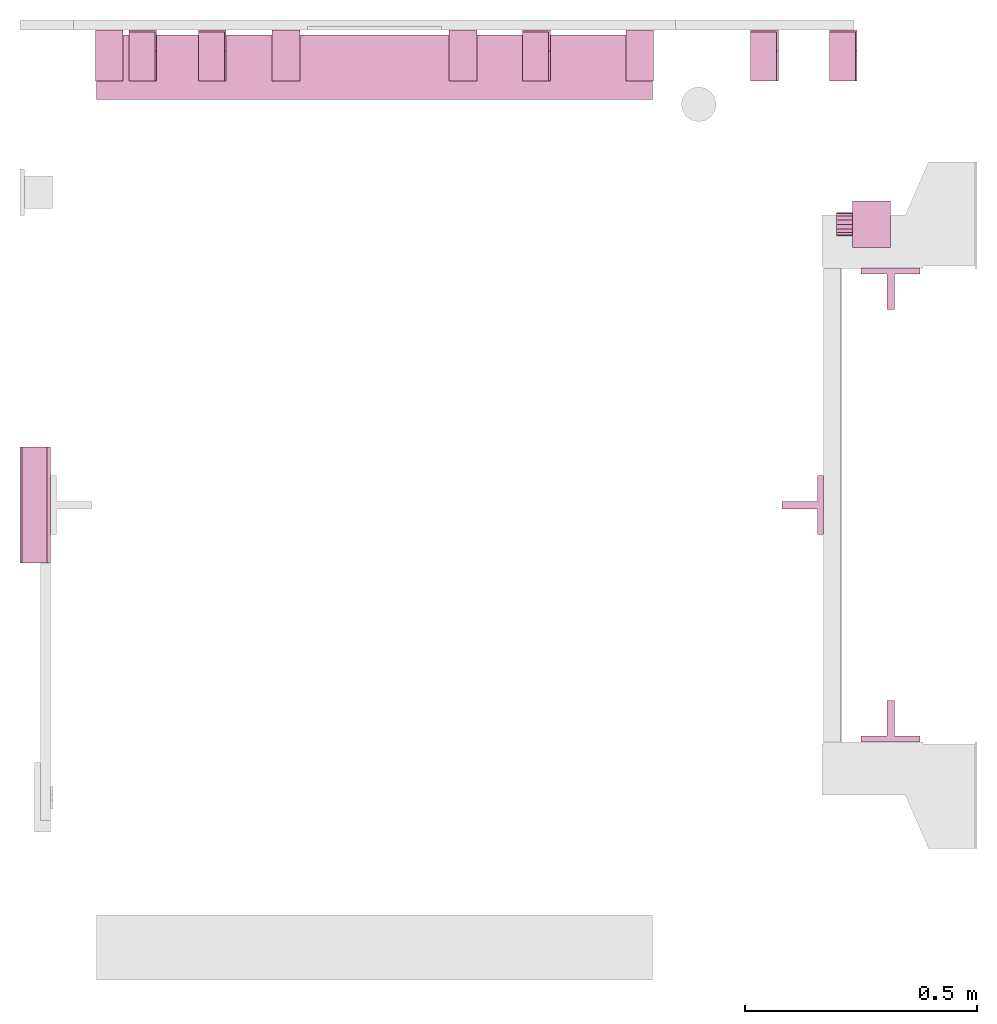
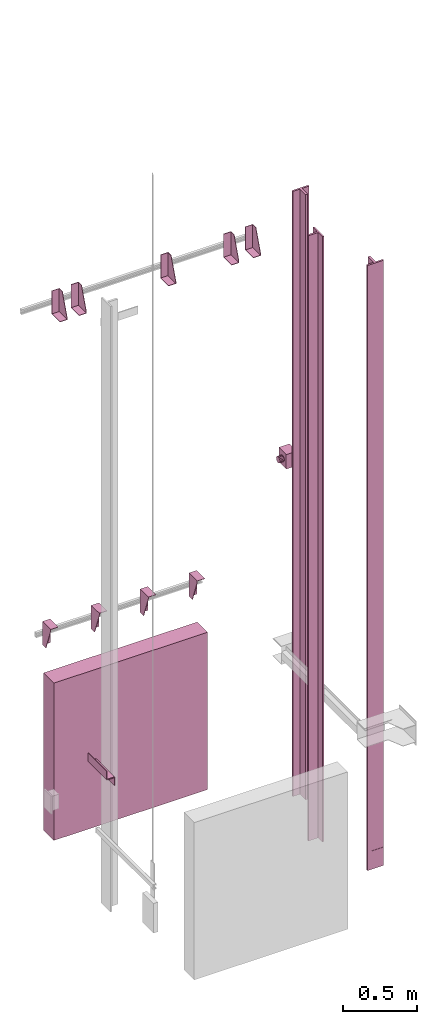
# One storey, part 5 of 5: 15 transport elements.
"""IFC4 building model written with IfcOpenShell, lengths in millimetres."""

from ifc_helpers import new_model, entity, si_unit, converted_unit, frame, origin_with_axes, place, context, subcontext, project, spatial, faceted_brep, element, save


model = new_model("IFC4")

# Units and contexts
context_of_model = context(None, 3, precision=0.01, world=origin_with_axes())
sub_context_1 = subcontext(context_of_model, None, None, "MODEL_VIEW")
sub_context_2 = subcontext(context_of_model, None, None, "MODEL_VIEW")
sub_context_3 = subcontext(context_of_model, None, None, "MODEL_VIEW")
sub_context_4 = subcontext(context_of_model, None, None, "MODEL_VIEW")
sub_context_5 = subcontext(context_of_model, None, None, "MODEL_VIEW")
sub_context_6 = subcontext(context_of_model, None, None, "MODEL_VIEW")
sub_context_7 = subcontext(context_of_model, None, None, "MODEL_VIEW")
sub_context_8 = subcontext(context_of_model, None, None, "MODEL_VIEW")
sub_context_9 = subcontext(context_of_model, None, None, "MODEL_VIEW")
sub_context_10 = subcontext(context_of_model, None, None, "MODEL_VIEW")
sub_context_11 = subcontext(context_of_model, None, None, "MODEL_VIEW")
sub_context_12 = subcontext(context_of_model, None, None, "MODEL_VIEW")
sub_context_13 = subcontext(context_of_model, None, None, "MODEL_VIEW")
sub_context_14 = subcontext(context_of_model, None, None, "MODEL_VIEW")
sub_context_15 = subcontext(context_of_model, None, None, "MODEL_VIEW")
ifc_project = project(units=[converted_unit("PLANEANGLEUNIT", "degree", entity("IfcPlaneAngleMeasure", 0.017453292519943), si_unit("PLANEANGLEUNIT", "RADIAN"), dimensions=[0, 0, 0, 0, 0, 0, 0]), si_unit("LENGTHUNIT", "METRE", prefix="MILLI"), si_unit("MASSUNIT", "GRAM", prefix="KILO"), converted_unit("TIMEUNIT", "year", entity("IfcTimeMeasure", 31557600.0), si_unit("TIMEUNIT", "SECOND"), dimensions=[0, 0, 1, 0, 0, 0, 0]), si_unit("THERMODYNAMICTEMPERATUREUNIT", "DEGREE_CELSIUS"), si_unit("AREAUNIT", "SQUARE_METRE"), si_unit("FORCEUNIT", "NEWTON"), si_unit("VOLUMEUNIT", "CUBIC_METRE"), si_unit("PRESSUREUNIT", "PASCAL"), si_unit("SOLIDANGLEUNIT", "STERADIAN")], contexts=[context_of_model])

# Site, building, storey
site = spatial("IfcSite", under=ifc_project)
building = spatial("IfcBuilding", under=site, Name="Document")
placement = place(None, origin_with_axes())
storey_placement = place(placement, frame((0.0, 0.0, -24650.0), z_axis=(0.0, 0.0, 1.0), x_axis=(1.0, 0.0, 0.0)))
storey = spatial("IfcBuildingStorey", under=building, at=storey_placement, Name="P11", Elevation=-24650.0)

# Transport elements
transport_element_1_placement = place(storey_placement, frame((1879.0, 558.5, 763.0), z_axis=(0.0, -1.0, 0.0), x_axis=(0.0, 0.0, -1.0)))
element("IfcTransportElement", 1, at=transport_element_1_placement, inside=storey, ObjectType="Guide Rail", PredefinedType="ELEVATOR", context=sub_context_1, shape_type="Brep", body=[
    faceted_brep([(-2500.0, -63.5, 44.5), (-2500.0, -63.5, 31.79998779296875), (2500.0, -63.5, 31.79998779296875), (2500.0, -63.5, 44.5), (-2500.0, -7.93994140625, 31.79998779296875), (-2500.0, -7.93994140625, -44.5), (2500.0, -7.93994140625, -44.5), (2500.0, -7.93994140625, 31.79998779296875), (2500.0, 7.93994140625, -44.5), (-2500.0, 7.93994140625, -44.5), (-2500.0, 7.93994140625, 31.79998779296875), (2500.0, 7.93994140625, 31.79998779296875), (2500.0, 63.5, 31.79998779296875), (-2500.0, 63.5, 31.79998779296875), (-2500.0, 63.5, 44.5), (2500.0, 63.5, 44.5)], [[[0, 1, 2, 3]], [[4, 5, 6, 7]], [[8, 9, 10, 11]], [[12, 13, 14, 15]], [[15, 14, 0, 3]], [[1, 4, 7, 2]], [[10, 13, 12, 11]], [[5, 9, 8, 6]], [[2, 7, 6, 8, 11, 12, 15, 3]], [[14, 13, 10, 9, 5, 4, 1, 0]]]),
    faceted_brep([(2347.5, -63.5, 45.0), (2347.5, 63.5, 45.0), (2347.5, 63.5, 44.0), (2347.5, -63.5, 44.0), (2500.0, -63.5, 45.0), (2500.0, -63.5, 44.0), (2500.0, 63.5, 44.0), (2500.0, 63.5, 45.0)], [[[0, 1, 2, 3]], [[4, 5, 6, 7]], [[0, 3, 5, 4]], [[3, 2, 6, 5]], [[2, 1, 7, 6]], [[1, 0, 4, 7]]]),
    faceted_brep([(-2500.0, -63.5, 45.0), (-2500.0, 63.5, 45.0), (-2500.0, 63.5, 44.0), (-2500.0, -63.5, 44.0), (-2347.5, -63.5, 45.0), (-2347.5, -63.5, 44.0), (-2347.5, 63.5, 44.0), (-2347.5, 63.5, 45.0)], [[[0, 1, 2, 3]], [[4, 5, 6, 7]], [[0, 3, 5, 4]], [[3, 2, 6, 5]], [[2, 1, 7, 6]], [[1, 0, 4, 7]]]),
])
transport_element_2_placement = place(storey_placement, frame((1879.0, 1491.5, 763.0), z_axis=(0.0, 1.0, 0.0), x_axis=(0.0, 0.0, 1.0)))
element("IfcTransportElement", 2, at=transport_element_2_placement, inside=storey, ObjectType="Guide Rail", PredefinedType="ELEVATOR", context=sub_context_2, shape_type="Brep", body=[
    faceted_brep([(2500.0, -63.5, 31.800048828125), (2500.0, -63.5, 44.5), (-2500.0, -63.5, 44.5), (-2500.0, -63.5, 31.800048828125), (2500.0, -7.93994140625, -44.5), (2500.0, -7.93994140625, 31.800048828125), (-2500.0, -7.93994140625, 31.800048828125), (-2500.0, -7.93994140625, -44.5), (-2500.0, 7.93994140625, 31.800048828125), (2500.0, 7.93994140625, 31.800048828125), (2500.0, 7.93994140625, -44.5), (-2500.0, 7.93994140625, -44.5), (-2500.0, 63.5, 44.5), (2500.0, 63.5, 44.5), (2500.0, 63.5, 31.800048828125), (-2500.0, 63.5, 31.800048828125)], [[[0, 1, 2, 3]], [[4, 5, 6, 7]], [[8, 9, 10, 11]], [[12, 13, 14, 15]], [[6, 5, 0, 3]], [[1, 13, 12, 2]], [[11, 10, 4, 7]], [[9, 8, 15, 14]], [[2, 12, 15, 8, 11, 7, 6, 3]], [[5, 4, 10, 9, 14, 13, 1, 0]]]),
    faceted_brep([(2347.5, -63.5, 45.0), (2347.5, 63.5, 45.0), (2347.5, 63.5, 44.0), (2347.5, -63.5, 44.0), (2500.0, -63.5, 45.0), (2500.0, -63.5, 44.0), (2500.0, 63.5, 44.0), (2500.0, 63.5, 45.0)], [[[0, 1, 2, 3]], [[4, 5, 6, 7]], [[0, 3, 5, 4]], [[3, 2, 6, 5]], [[2, 1, 7, 6]], [[1, 0, 4, 7]]]),
    faceted_brep([(-2500.0, -63.5, 45.0), (-2500.0, 63.5, 45.0), (-2500.0, 63.5, 44.0), (-2500.0, -63.5, 44.0), (-2347.5, -63.5, 45.0), (-2347.5, -63.5, 44.0), (-2347.5, 63.5, 44.0), (-2347.5, 63.5, 45.0)], [[[0, 1, 2, 3]], [[4, 5, 6, 7]], [[0, 3, 5, 4]], [[3, 2, 6, 5]], [[2, 1, 7, 6]], [[1, 0, 4, 7]]]),
])
transport_element_3_placement = place(storey_placement, frame((1689.5, 1025.0, 763.0), z_axis=(1.0, 0.0, 0.0), x_axis=(0.0, 0.0, 1.0)))
element("IfcTransportElement", 3, at=transport_element_3_placement, inside=storey, ObjectType="Guide Rail", PredefinedType="ELEVATOR", context=sub_context_3, shape_type="Brep", body=[
    faceted_brep([(2500.0, 7.94000244140625, -44.5), (2500.0, -7.93994140625, -44.5), (-2500.0, -7.93994140625, -44.5), (-2500.0, 7.94000244140625, -44.5), (2500.0, 63.5, 31.800048828125), (2500.0, 7.94000244140625, 31.800048828125), (-2500.0, 7.94000244140625, 31.800048828125), (-2500.0, 63.5, 31.800048828125), (-2500.0, -63.5, 44.5), (2500.0, -63.5, 44.5), (2500.0, 63.5, 44.5), (-2500.0, 63.5, 44.5), (2500.0, -7.93994140625, 31.800048828125), (2500.0, -63.5, 31.800048828125), (-2500.0, -63.5, 31.800048828125), (-2500.0, -7.93994140625, 31.800048828125)], [[[0, 1, 2, 3]], [[4, 5, 6, 7]], [[8, 9, 10, 11]], [[12, 13, 14, 15]], [[6, 5, 0, 3]], [[1, 12, 15, 2]], [[11, 10, 4, 7]], [[13, 9, 8, 14]], [[2, 15, 14, 8, 11, 7, 6, 3]], [[5, 4, 10, 9, 13, 12, 1, 0]]]),
    faceted_brep([(2347.5, -63.5, 45.0), (2347.5, 63.5, 45.0), (2347.5, 63.5, 44.0), (2347.5, -63.5, 44.0), (2500.0, -63.5, 45.0), (2500.0, -63.5, 44.0), (2500.0, 63.5, 44.0), (2500.0, 63.5, 45.0)], [[[0, 1, 2, 3]], [[4, 5, 6, 7]], [[0, 3, 5, 4]], [[3, 2, 6, 5]], [[2, 1, 7, 6]], [[1, 0, 4, 7]]]),
    faceted_brep([(-2500.0, -63.5, 45.0), (-2500.0, 63.5, 45.0), (-2500.0, 63.5, 44.0), (-2500.0, -63.5, 44.0), (-2347.5, -63.5, 45.0), (-2347.5, -63.5, 44.0), (-2347.5, 63.5, 44.0), (-2347.5, 63.5, 45.0)], [[[0, 1, 2, 3]], [[4, 5, 6, 7]], [[0, 3, 5, 4]], [[3, 2, 6, 5]], [[2, 1, 7, 6]], [[1, 0, 4, 7]]]),
])
transport_element_4_placement = place(storey_placement, frame((765.0, 1970.0, -1750.0), z_axis=(0.0, 0.0, 1.0), x_axis=(1.0, 0.0, 0.0)))
element("IfcTransportElement", 4, at=transport_element_4_placement, inside=storey, PredefinedType="ELEVATOR", context=sub_context_4, shape_type="Brep", body=[
    faceted_brep([(-600.0, -70.0, 1300.0), (-600.0, 70.0, 1300.0), (-600.0, 70.0, 0.0), (-600.0, -70.0, 0.0), (600.0, -70.0, 1300.0), (600.0, -70.0, 0.0), (600.0, 70.0, 0.0), (600.0, 70.0, 1300.0)], [[[0, 1, 2, 3]], [[4, 5, 6, 7]], [[0, 3, 5, 4]], [[3, 2, 6, 5]], [[2, 1, 7, 6]], [[1, 0, 4, 7]]]),
])
transport_element_5_placement = place(storey_placement, frame((1777.0, 2050.0, 2580.0), z_axis=(0.0, 0.0, 1.0), x_axis=(-1.0, 0.0, 0.0)))
element("IfcTransportElement", 5, at=transport_element_5_placement, inside=storey, PredefinedType="ELEVATOR", context=sub_context_5, shape_type="Brep", body=[
    faceted_brep([(30.0, 110.0, -93.0), (30.0, 4.0, -93.0), (30.0, 4.0, 97.0), (30.0, 0.0, 97.0), (30.0, 0.0, -97.0), (30.0, 110.0, -97.0), (-30.0, 0.0, -97.0), (-30.0, 0.0, 97.0), (-30.0, 4.0, 97.0), (-30.0, 4.0, -93.0), (-30.0, 110.0, -93.0), (-30.0, 110.0, -97.0)], [[[0, 1, 2, 3, 4, 5]], [[6, 7, 8, 9, 10, 11]], [[11, 10, 0, 5]], [[9, 8, 2, 1]], [[3, 7, 6, 4]], [[4, 6, 11, 5]], [[10, 9, 1, 0]], [[8, 7, 3, 2]]]),
    faceted_brep([(-30.0, 4.0, -93.0), (-30.0, 4.0, 97.0), (-30.0, 45.0, 97.0), (-30.0, 110.0, -82.0), (-30.0, 110.0, -93.0), (-26.0, 4.0, -93.0), (-26.0, 110.0, -93.0), (-26.0, 110.0, -82.0), (-26.0, 45.0, 97.0), (-26.0, 4.0, 97.0)], [[[0, 1, 2, 3, 4]], [[5, 6, 7, 8, 9]], [[5, 0, 4, 6]], [[6, 4, 3, 7]], [[7, 3, 2, 8]], [[8, 2, 1, 9]], [[9, 1, 0, 5]]]),
])
transport_element_6_placement = place(storey_placement, frame((1607.0, 2050.0, 2580.0), z_axis=(0.0, 0.0, 1.0), x_axis=(-1.0, 0.0, 0.0)))
element("IfcTransportElement", 6, at=transport_element_6_placement, inside=storey, PredefinedType="ELEVATOR", context=sub_context_6, shape_type="Brep", body=[
    faceted_brep([(30.0, 110.0, -93.0), (30.0, 4.0, -93.0), (30.0, 4.0, 97.0), (30.0, 0.0, 97.0), (30.0, 0.0, -97.0), (30.0, 110.0, -97.0), (-30.0, 0.0, -97.0), (-30.0, 0.0, 97.0), (-30.0, 4.0, 97.0), (-30.0, 4.0, -93.0), (-30.0, 110.0, -93.0), (-30.0, 110.0, -97.0)], [[[0, 1, 2, 3, 4, 5]], [[6, 7, 8, 9, 10, 11]], [[11, 10, 0, 5]], [[9, 8, 2, 1]], [[3, 7, 6, 4]], [[4, 6, 11, 5]], [[10, 9, 1, 0]], [[8, 7, 3, 2]]]),
    faceted_brep([(-30.0, 4.0, -93.0), (-30.0, 4.0, 97.0), (-30.0, 45.0, 97.0), (-30.0, 110.0, -82.0), (-30.0, 110.0, -93.0), (-26.0, 4.0, -93.0), (-26.0, 110.0, -93.0), (-26.0, 110.0, -82.0), (-26.0, 45.0, 97.0), (-26.0, 4.0, 97.0)], [[[0, 1, 2, 3, 4]], [[5, 6, 7, 8, 9]], [[5, 0, 4, 6]], [[6, 4, 3, 7]], [[7, 3, 2, 8]], [[8, 2, 1, 9]], [[9, 1, 0, 5]]]),
])
transport_element_7_placement = place(storey_placement, frame((1115.0, 2050.0, 2580.0), z_axis=(0.0, 0.0, 1.0), x_axis=(-1.0, 0.0, 0.0)))
element("IfcTransportElement", 7, at=transport_element_7_placement, inside=storey, PredefinedType="ELEVATOR", context=sub_context_7, shape_type="Brep", body=[
    faceted_brep([(-30.0, 4.0, -93.0), (-30.0, 4.0, 97.0), (-30.0, 45.0, 97.0), (-30.0, 110.0, -82.0), (-30.0, 110.0, -93.0), (-26.0, 4.0, -93.0), (-26.0, 110.0, -93.0), (-26.0, 110.0, -82.0), (-26.0, 45.0, 97.0), (-26.0, 4.0, 97.0)], [[[0, 1, 2, 3, 4]], [[5, 6, 7, 8, 9]], [[5, 0, 4, 6]], [[6, 4, 3, 7]], [[7, 3, 2, 8]], [[8, 2, 1, 9]], [[9, 1, 0, 5]]]),
    faceted_brep([(30.0, 110.0, -93.0), (30.0, 4.0, -93.0), (30.0, 4.0, 97.0), (30.0, 0.0, 97.0), (30.0, 0.0, -97.0), (30.0, 110.0, -97.0), (-30.0, 0.0, -97.0), (-30.0, 0.0, 97.0), (-30.0, 4.0, 97.0), (-30.0, 4.0, -93.0), (-30.0, 110.0, -93.0), (-30.0, 110.0, -97.0)], [[[0, 1, 2, 3, 4, 5]], [[6, 7, 8, 9, 10, 11]], [[11, 10, 0, 5]], [[9, 8, 2, 1]], [[3, 7, 6, 4]], [[4, 6, 11, 5]], [[10, 9, 1, 0]], [[8, 7, 3, 2]]]),
])
transport_element_8_placement = place(storey_placement, frame((415.0, 2050.0, 2580.0), z_axis=(0.0, 0.0, 1.0), x_axis=(-1.0, 0.0, 0.0)))
element("IfcTransportElement", 8, at=transport_element_8_placement, inside=storey, PredefinedType="ELEVATOR", context=sub_context_8, shape_type="Brep", body=[
    faceted_brep([(30.0, 110.0, -93.0), (30.0, 4.0, -93.0), (30.0, 4.0, 97.0), (30.0, 0.0, 97.0), (30.0, 0.0, -97.0), (30.0, 110.0, -97.0), (-30.0, 0.0, -97.0), (-30.0, 0.0, 97.0), (-30.0, 4.0, 97.0), (-30.0, 4.0, -93.0), (-30.0, 110.0, -93.0), (-30.0, 110.0, -97.0)], [[[0, 1, 2, 3, 4, 5]], [[6, 7, 8, 9, 10, 11]], [[11, 10, 0, 5]], [[9, 8, 2, 1]], [[3, 7, 6, 4]], [[4, 6, 11, 5]], [[10, 9, 1, 0]], [[8, 7, 3, 2]]]),
    faceted_brep([(-30.0, 4.0, -93.0), (-30.0, 4.0, 97.0), (-30.0, 45.0, 97.0), (-30.0, 110.0, -82.0), (-30.0, 110.0, -93.0), (-26.0, 4.0, -93.0), (-26.0, 110.0, -93.0), (-26.0, 110.0, -82.0), (-26.0, 45.0, 97.0), (-26.0, 4.0, 97.0)], [[[0, 1, 2, 3, 4]], [[5, 6, 7, 8, 9]], [[5, 0, 4, 6]], [[6, 4, 3, 7]], [[7, 3, 2, 8]], [[8, 2, 1, 9]], [[9, 1, 0, 5]]]),
])
transport_element_9_placement = place(storey_placement, frame((265.0, 2050.0, 2580.0), z_axis=(0.0, 0.0, 1.0), x_axis=(-1.0, 0.0, 0.0)))
element("IfcTransportElement", 9, at=transport_element_9_placement, inside=storey, PredefinedType="ELEVATOR", context=sub_context_9, shape_type="Brep", body=[
    faceted_brep([(30.0, 110.0, -93.0), (30.0, 4.0, -93.0), (30.0, 4.0, 97.0), (30.0, 0.0, 97.0), (30.0, 0.0, -97.0), (30.0, 110.0, -97.0), (-30.0, 0.0, -97.0), (-30.0, 0.0, 97.0), (-30.0, 4.0, 97.0), (-30.0, 4.0, -93.0), (-30.0, 110.0, -93.0), (-30.0, 110.0, -97.0)], [[[0, 1, 2, 3, 4, 5]], [[6, 7, 8, 9, 10, 11]], [[11, 10, 0, 5]], [[9, 8, 2, 1]], [[3, 7, 6, 4]], [[4, 6, 11, 5]], [[10, 9, 1, 0]], [[8, 7, 3, 2]]]),
    faceted_brep([(-30.0, 4.0, -93.0), (-30.0, 4.0, 97.0), (-30.0, 45.0, 97.0), (-30.0, 110.0, -82.0), (-30.0, 110.0, -93.0), (-26.0, 4.0, -93.0), (-26.0, 110.0, -93.0), (-26.0, 110.0, -82.0), (-26.0, 45.0, 97.0), (-26.0, 4.0, 97.0)], [[[0, 1, 2, 3, 4]], [[5, 6, 7, 8, 9]], [[5, 0, 4, 6]], [[6, 4, 3, 7]], [[7, 3, 2, 8]], [[8, 2, 1, 9]], [[9, 1, 0, 5]]]),
])
transport_element_10_placement = place(storey_placement, frame((192.5, 2050.0, -30.0), z_axis=(0.0, 0.0, -1.0), x_axis=(1.0, 0.0, 0.0)))
element("IfcTransportElement", 10, at=transport_element_10_placement, inside=storey, PredefinedType="ELEVATOR", context=sub_context_10, shape_type="Brep", body=[
    faceted_brep([(-30.0, 4.0, 4.0), (-30.0, 110.0, 4.0), (-30.0, 110.0, 0.0), (-30.0, 0.0, 0.0), (-30.0, 0.0, 194.0), (-30.0, 4.0, 194.0), (30.0, 0.0, 194.0), (30.0, 0.0, 0.0), (30.0, 110.0, 0.0), (30.0, 110.0, 4.0), (30.0, 4.0, 4.0), (30.0, 4.0, 194.0)], [[[0, 1, 2, 3, 4, 5]], [[6, 7, 8, 9, 10, 11]], [[11, 10, 0, 5]], [[3, 7, 6, 4]], [[9, 8, 2, 1]], [[4, 6, 11, 5]], [[0, 10, 9, 1]], [[8, 7, 3, 2]]]),
    faceted_brep([(-30.0, 4.0, 4.0), (-30.0, 4.0, 194.0), (-30.0, 45.0, 194.0), (-30.0, 110.0, 15.0), (-30.0, 110.0, 4.0), (-26.0, 4.0, 4.0), (-26.0, 110.0, 4.0), (-26.0, 110.0, 15.0), (-26.0, 45.0, 194.0), (-26.0, 4.0, 194.0)], [[[0, 1, 2, 3, 4]], [[5, 6, 7, 8, 9]], [[5, 0, 4, 6]], [[6, 4, 3, 7]], [[7, 3, 2, 8]], [[8, 2, 1, 9]], [[9, 1, 0, 5]]]),
])
transport_element_11_placement = place(storey_placement, frame((573.84, 2050.0, -30.0), z_axis=(0.0, 0.0, -1.0), x_axis=(1.0, 0.0, 0.0)))
element("IfcTransportElement", 11, at=transport_element_11_placement, inside=storey, PredefinedType="ELEVATOR", context=sub_context_11, shape_type="Brep", body=[
    faceted_brep([(-29.999973144531282, 4.0, 4.0), (-29.999973144531282, 110.0, 4.0), (-29.999973144531282, 110.0, 0.0), (-29.999973144531282, 0.0, 0.0), (-29.999973144531282, 0.0, 194.0), (-29.999973144531282, 4.0, 194.0), (30.000026855468718, 0.0, 194.0), (30.000026855468718, 0.0, 0.0), (30.000026855468718, 110.0, 0.0), (30.000026855468718, 110.0, 4.0), (30.000026855468718, 4.0, 4.0), (30.000026855468718, 4.0, 194.0)], [[[0, 1, 2, 3, 4, 5]], [[6, 7, 8, 9, 10, 11]], [[11, 10, 0, 5]], [[3, 7, 6, 4]], [[9, 8, 2, 1]], [[4, 6, 11, 5]], [[0, 10, 9, 1]], [[8, 7, 3, 2]]]),
    faceted_brep([(-29.999973144531282, 4.0, 4.0), (-29.999973144531282, 4.0, 194.0), (-29.999973144531282, 45.0, 194.0), (-29.999973144531282, 110.0, 15.0), (-29.999973144531282, 110.0, 4.0), (-25.999973144531282, 4.0, 4.0), (-25.999973144531282, 110.0, 4.0), (-25.999973144531282, 110.0, 15.0), (-25.999973144531282, 45.0, 194.0), (-25.999973144531282, 4.0, 194.0)], [[[0, 1, 2, 3, 4]], [[5, 6, 7, 8, 9]], [[5, 0, 4, 6]], [[6, 4, 3, 7]], [[7, 3, 2, 8]], [[8, 2, 1, 9]], [[9, 1, 0, 5]]]),
])
transport_element_12_placement = place(storey_placement, frame((956.16, 2050.0, -30.0), z_axis=(0.0, 0.0, -1.0), x_axis=(1.0, 0.0, 0.0)))
element("IfcTransportElement", 12, at=transport_element_12_placement, inside=storey, PredefinedType="ELEVATOR", context=sub_context_12, shape_type="Brep", body=[
    faceted_brep([(-30.000026855468718, 4.0, 4.0), (-30.000026855468718, 4.0, 194.0), (-30.000026855468718, 45.0, 194.0), (-30.000026855468718, 110.0, 15.0), (-30.000026855468718, 110.0, 4.0), (-26.000026855468718, 4.0, 4.0), (-26.000026855468718, 110.0, 4.0), (-26.000026855468718, 110.0, 15.0), (-26.000026855468718, 45.0, 194.0), (-26.000026855468718, 4.0, 194.0)], [[[0, 1, 2, 3, 4]], [[5, 6, 7, 8, 9]], [[5, 0, 4, 6]], [[6, 4, 3, 7]], [[7, 3, 2, 8]], [[8, 2, 1, 9]], [[9, 1, 0, 5]]]),
    faceted_brep([(-30.000026855468718, 4.0, 4.0), (-30.000026855468718, 110.0, 4.0), (-30.000026855468718, 110.0, 0.0), (-30.000026855468718, 0.0, 0.0), (-30.000026855468718, 0.0, 194.0), (-30.000026855468718, 4.0, 194.0), (29.999973144531282, 0.0, 194.0), (29.999973144531282, 0.0, 0.0), (29.999973144531282, 110.0, 0.0), (29.999973144531282, 110.0, 4.0), (29.999973144531282, 4.0, 4.0), (29.999973144531282, 4.0, 194.0)], [[[0, 1, 2, 3, 4, 5]], [[6, 7, 8, 9, 10, 11]], [[11, 10, 0, 5]], [[3, 7, 6, 4]], [[9, 8, 2, 1]], [[4, 6, 11, 5]], [[0, 10, 9, 1]], [[8, 7, 3, 2]]]),
])
transport_element_13_placement = place(storey_placement, frame((1337.5, 2050.0, -30.0), z_axis=(0.0, 0.0, -1.0), x_axis=(1.0, 0.0, 0.0)))
element("IfcTransportElement", 13, at=transport_element_13_placement, inside=storey, PredefinedType="ELEVATOR", context=sub_context_13, shape_type="Brep", body=[
    faceted_brep([(-30.0, 4.0, 4.0), (-30.0, 110.0, 4.0), (-30.0, 110.0, 0.0), (-30.0, 0.0, 0.0), (-30.0, 0.0, 194.0), (-30.0, 4.0, 194.0), (30.0, 0.0, 194.0), (30.0, 0.0, 0.0), (30.0, 110.0, 0.0), (30.0, 110.0, 4.0), (30.0, 4.0, 4.0), (30.0, 4.0, 194.0)], [[[0, 1, 2, 3, 4, 5]], [[6, 7, 8, 9, 10, 11]], [[11, 10, 0, 5]], [[3, 7, 6, 4]], [[9, 8, 2, 1]], [[4, 6, 11, 5]], [[0, 10, 9, 1]], [[8, 7, 3, 2]]]),
    faceted_brep([(-30.0, 4.0, 4.0), (-30.0, 4.0, 194.0), (-30.0, 45.0, 194.0), (-30.0, 110.0, 15.0), (-30.0, 110.0, 4.0), (-26.0, 4.0, 4.0), (-26.0, 110.0, 4.0), (-26.0, 110.0, 15.0), (-26.0, 45.0, 194.0), (-26.0, 4.0, 194.0)], [[[0, 1, 2, 3, 4]], [[5, 6, 7, 8, 9]], [[5, 0, 4, 6]], [[6, 4, 3, 7]], [[7, 3, 2, 8]], [[8, 2, 1, 9]], [[9, 1, 0, 5]]]),
])
transport_element_14_placement = place(storey_placement, frame((0.0, 1025.0, -550.0), z_axis=(0.0, 0.0, 1.0), x_axis=(0.0, -1.0, 0.0)))
element("IfcTransportElement", 14, at=transport_element_14_placement, inside=storey, PredefinedType="ELEVATOR", context=sub_context_14, shape_type="Brep", body=[
    faceted_brep([(125.0, 8.0, -35.0), (-125.0, 8.0, -35.0), (-125.0, 8.0, -39.0), (125.0, 8.0, -39.0), (125.0, 62.0, -39.0), (-125.0, 62.0, -39.0), (-125.0, 62.0, -105.0), (125.0, 62.0, -105.0), (-125.0, 66.0, -105.0), (-125.0, 66.0, -35.0), (125.0, 66.0, -35.0), (125.0, 66.0, -105.0)], [[[0, 1, 2, 3]], [[4, 5, 6, 7]], [[8, 9, 10, 11]], [[4, 7, 11, 10, 0, 3]], [[1, 9, 8, 6, 5, 2]], [[2, 5, 4, 3]], [[10, 9, 1, 0]], [[6, 8, 11, 7]]]),
    faceted_brep([(125.0, 0.0, 35.0), (-125.0, 0.0, 35.0), (-125.0, 0.0, -35.0), (125.0, 0.0, -35.0), (-125.0, 4.0, -31.0), (-125.0, 4.0, 35.0), (125.0, 4.0, 35.0), (125.0, 4.0, -31.0), (-125.0, 58.0, -35.0), (-125.0, 58.0, -31.0), (125.0, 58.0, -31.0), (125.0, 58.0, -35.0)], [[[0, 1, 2, 3]], [[4, 5, 6, 7]], [[8, 9, 10, 11]], [[11, 10, 7, 6, 0, 3]], [[2, 1, 5, 4, 9, 8]], [[2, 8, 11, 3]], [[10, 9, 4, 7]], [[6, 5, 1, 0]]]),
])
transport_element_15_placement = place(storey_placement, frame((1879.0, 1631.0, 1000.0), z_axis=(0.0, 0.0, 1.0), x_axis=(0.0, 1.0, 0.0)))
element("IfcTransportElement", 15, at=transport_element_15_placement, inside=storey, PredefinedType="ELEVATOR", context=sub_context_15, shape_type="Brep", body=[
    faceted_brep([(2.27e-13, 82.0, 25.0), (-9.567138671874773, 82.0, 23.096923828125), (-17.677612304687273, 82.0, 17.677734375), (-23.097045898437273, 82.0, 9.567138671875), (-24.999999999999773, 82.0, 0.0), (-23.097045898437273, 82.0, -9.567138671875), (-17.677612304687273, 82.0, -17.677734375), (-9.567138671874773, 82.0, -23.096923828125), (2.27e-13, 82.0, -25.0), (9.567138671875227, 82.0, -23.096923828125), (17.677612304687727, 82.0, -17.677734375), (23.097045898437727, 82.0, -9.567138671875), (25.000000000000227, 82.0, 0.0), (23.097045898437727, 82.0, 9.567138671875), (17.677612304687727, 82.0, 17.677734375), (9.567138671875227, 82.0, 23.096923828125), (2.27e-13, 117.0, 25.0), (9.567138671875227, 117.0, 23.096923828125), (17.677612304687727, 117.0, 17.677734375), (23.097045898437727, 117.0, 9.567138671875), (25.000000000000227, 117.0, 0.0), (23.097045898437727, 117.0, -9.567138671875), (17.677612304687727, 117.0, -17.677734375), (9.567138671875227, 117.0, -23.096923828125), (2.27e-13, 117.0, -25.0), (-9.567138671874773, 117.0, -23.096923828125), (-17.677612304687273, 117.0, -17.677734375), (-23.097045898437273, 117.0, -9.567138671875), (-24.999999999999773, 117.0, 0.0), (-23.097045898437273, 117.0, 9.567138671875), (-17.677612304687273, 117.0, 17.677734375), (-9.567138671874773, 117.0, 23.096923828125)], [[[0, 1, 2, 3, 4, 5, 6, 7, 8, 9, 10, 11, 12, 13, 14, 15]], [[16, 17, 18, 19, 20, 21, 22, 23, 24, 25, 26, 27, 28, 29, 30, 31]], [[0, 15, 17, 16]], [[15, 14, 18, 17]], [[14, 13, 19, 18]], [[13, 12, 20, 19]], [[12, 11, 21, 20]], [[11, 10, 22, 21]], [[10, 9, 23, 22]], [[9, 8, 24, 23]], [[8, 7, 25, 24]], [[7, 6, 26, 25]], [[6, 5, 27, 26]], [[5, 4, 28, 27]], [[4, 3, 29, 28]], [[3, 2, 30, 29]], [[2, 1, 31, 30]], [[1, 0, 16, 31]]]),
    faceted_brep([(50.0, 0.0, 60.0), (50.00000000000023, 82.0, 60.0), (-49.99999999999977, 82.0, 60.0), (-50.0, 0.0, 60.0), (50.0, 0.0, -60.0), (-50.0, 0.0, -60.0), (-49.99999999999977, 82.0, -60.0), (50.00000000000023, 82.0, -60.0)], [[[0, 1, 2, 3]], [[4, 5, 6, 7]], [[0, 3, 5, 4]], [[3, 2, 6, 5]], [[2, 1, 7, 6]], [[1, 0, 4, 7]]]),
])

save(model, "model.ifc")
